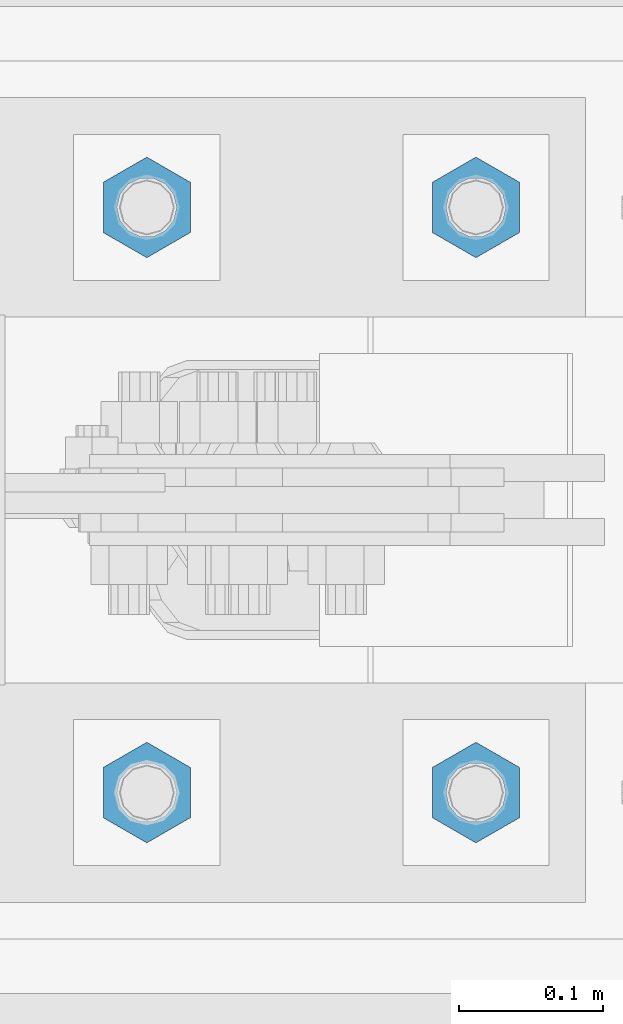
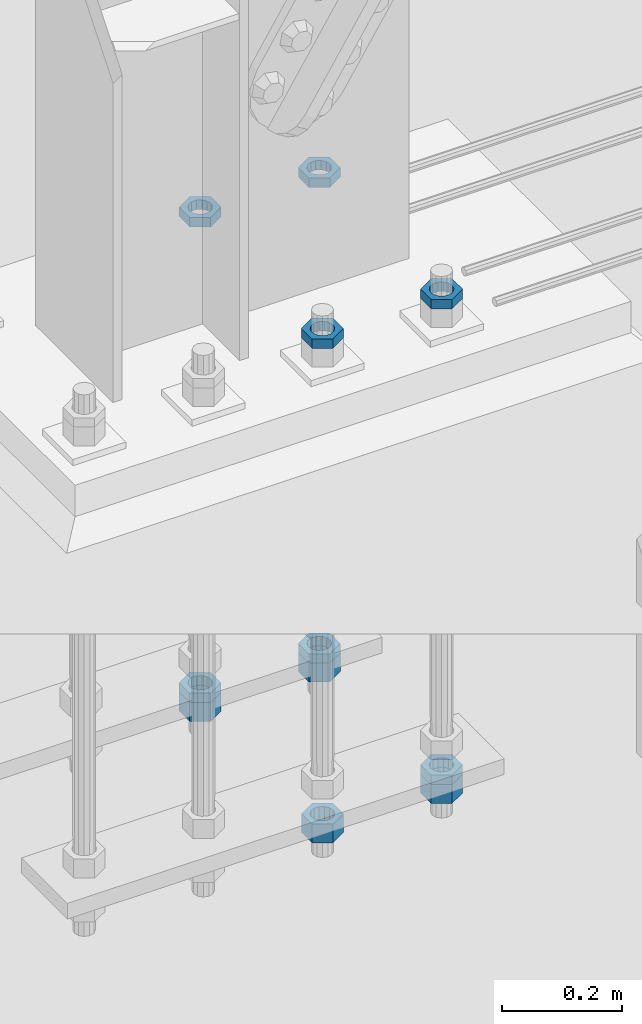
# One storey, part 2864 of 3843: 11 beams, 1 element without a shape of its own.
"""IFC2X3 building model written with IfcOpenShell, lengths in millimetres."""

from ifc_helpers import new_model, si_unit, frame, origin_with_axes, place, context, subcontext, project, spatial, faceted_brep, material, type_object, element, aggregate, save


model = new_model("IFC2X3")

# Units and contexts
model_context = context("Model", 3, precision=1e-05, world=origin_with_axes())
body_context = subcontext(model_context, "Body", "Model", "MODEL_VIEW")
ifc_project = project(units=[si_unit("LENGTHUNIT", "METRE", prefix="MILLI"), si_unit("AREAUNIT", "SQUARE_METRE"), si_unit("VOLUMEUNIT", "CUBIC_METRE"), si_unit("MASSUNIT", "GRAM", prefix="KILO"), si_unit("TIMEUNIT", "SECOND"), si_unit("PLANEANGLEUNIT", "RADIAN"), si_unit("SOLIDANGLEUNIT", "STERADIAN"), si_unit("THERMODYNAMICTEMPERATUREUNIT", "DEGREE_CELSIUS"), si_unit("LUMINOUSINTENSITYUNIT", "LUMEN")], contexts=[model_context])

# Site, building, storey
site_placement = place(None, origin_with_axes())
site = spatial("IfcSite", under=ifc_project, at=site_placement, CompositionType="ELEMENT")
building_placement = place(site_placement, origin_with_axes())
building = spatial("IfcBuilding", under=site, at=building_placement, Name="Undefined", CompositionType="ELEMENT")
storey_placement = place(building_placement, origin_with_axes())
storey = spatial("IfcBuildingStorey", under=building, at=storey_placement, Name="Undefined", CompositionType="ELEMENT", Elevation=0.0)

# Assembly, beams
assembly_placement = place(storey_placement, origin_with_axes())
assembly = element("IfcElementAssembly", 1, at=assembly_placement, inside=storey, Name="TEMPLATE", AssemblyPlace="NOTDEFINED", PredefinedType="RIGID_FRAME")
ifc_material = material(Name="STEEL/A572-50")
beam_type_1 = type_object("IfcBeamType", Name="1-1/2_HEAVY_HEX_NUT", PredefinedType="NOTDEFINED")
beam_1_placement = place(assembly_placement, frame((23317.1999804674, 89319.1, 29210.0), z_axis=(-1.0, 0.0, 0.0), x_axis=(0.0, 0.0, -1.0)))
beam_1 = element("IfcBeam", 2, at=beam_1_placement, type_object=beam_type_1, material=ifc_material, Name="NUT", ObjectType="1-1/2_HEAVY_HEX_NUT", context=body_context, shape_type="Brep", body=[
    faceted_brep([(0.0, -34.9199981689453, 0.0), (0.0, -17.4599990844727, -30.25), (38.0999999999985, -17.4599990844727, -30.25), (38.0999999999985, -34.9199981689453, 0.0), (0.0, 17.4599990844727, -30.25), (38.0999999999985, 17.4599990844727, -30.25), (0.0, 34.9199981689453, 0.0), (38.0999999999985, 34.9199981689453, 0.0), (0.0, 17.4599990844727, 30.25), (38.0999999999985, 17.4599990844727, 30.25), (0.0, -17.4599990844727, 30.25), (38.0999999999985, -17.4599990844727, 30.25), (0.0, 0.0, 20.6399993896484), (0.0, 8.9553601105581, 18.5959968835959), (38.0999999999985, 8.9553601105581, 18.5959968835959), (38.0999999999985, 0.0, 20.6399993896484), (0.0, 16.1370013209525, 12.8688291298167), (38.0999999999985, 16.1370013209525, 12.8688291298167), (0.0, 20.1225115123816, 4.59283194104501), (38.0999999999985, 20.1225115123816, 4.59283194104501), (0.0, 20.1225115123816, -4.59283194104501), (38.0999999999985, 20.1225115123816, -4.59283194104501), (0.0, 16.1370013209525, -12.8688291298167), (38.0999999999985, 16.1370013209525, -12.8688291298167), (0.0, 8.9553601105581, -18.5959968835959), (38.0999999999985, 8.9553601105581, -18.5959968835959), (0.0, 0.0, -20.6399993896484), (38.0999999999985, 0.0, -20.6399993896484), (0.0, -8.9553601105581, -18.5959968835959), (38.0999999999985, -8.9553601105581, -18.5959968835959), (0.0, -16.1370013209525, -12.8688291298167), (38.0999999999985, -16.1370013209525, -12.8688291298167), (0.0, -20.1225115123816, -4.59283194104501), (38.0999999999985, -20.1225115123816, -4.59283194104501), (0.0, -20.1225115123816, 4.59283194104501), (38.0999999999985, -20.1225115123816, 4.59283194104501), (0.0, -16.1370013209525, 12.8688291298167), (38.0999999999985, -16.1370013209525, 12.8688291298167), (0.0, -8.9553601105581, 18.5959968835959), (38.0999999999985, -8.9553601105581, 18.5959968835959)], [[[0, 1, 2, 3]], [[1, 4, 5, 2]], [[4, 6, 7, 5]], [[6, 8, 9, 7]], [[8, 10, 11, 9]], [[10, 0, 3, 11]], [[12, 13, 14, 15]], [[13, 16, 17, 14]], [[16, 18, 19, 17]], [[18, 20, 21, 19]], [[20, 22, 23, 21]], [[22, 24, 25, 23]], [[24, 26, 27, 25]], [[26, 28, 29, 27]], [[28, 30, 31, 29]], [[30, 32, 33, 31]], [[32, 34, 35, 33]], [[34, 36, 37, 35]], [[36, 38, 39, 37]], [[38, 12, 15, 39]], [[5, 7, 9, 11, 3, 2], [17, 19, 21, 23, 25, 27, 29, 31, 33, 35, 37, 39, 15, 14]], [[10, 8, 6, 4, 1, 0], [38, 36, 34, 32, 30, 28, 26, 24, 22, 20, 18, 16, 13, 12]]]),
])
beam_2_placement = place(assembly_placement, frame((23317.2000195326, 88912.7, 29210.0), z_axis=(1.0, 0.0, 0.0), x_axis=(0.0, 0.0, -1.0)))
beam_2 = element("IfcBeam", 3, at=beam_2_placement, type_object=beam_type_1, material=ifc_material, Name="NUT", ObjectType="1-1/2_HEAVY_HEX_NUT", context=body_context, shape_type="Brep", body=[
    faceted_brep([(0.0, -34.9199981689453, 0.0), (0.0, -17.4599990844727, -30.25), (38.0999999999985, -17.4599990844727, -30.25), (38.0999999999985, -34.9199981689453, 0.0), (0.0, 17.4599990844727, -30.25), (38.0999999999985, 17.4599990844727, -30.25), (0.0, 34.9199981689453, 0.0), (38.0999999999985, 34.9199981689453, 0.0), (0.0, 17.4599990844727, 30.25), (38.0999999999985, 17.4599990844727, 30.25), (0.0, -17.4599990844727, 30.25), (38.0999999999985, -17.4599990844727, 30.25), (0.0, 0.0, 20.6399993896484), (0.0, 8.9553601105581, 18.5959968835959), (38.0999999999985, 8.9553601105581, 18.5959968835959), (38.0999999999985, 0.0, 20.6399993896484), (0.0, 16.1370013209525, 12.8688291298167), (38.0999999999985, 16.1370013209525, 12.8688291298167), (0.0, 20.1225115123816, 4.59283194104501), (38.0999999999985, 20.1225115123816, 4.59283194104501), (0.0, 20.1225115123816, -4.59283194104501), (38.0999999999985, 20.1225115123816, -4.59283194104501), (0.0, 16.1370013209525, -12.8688291298167), (38.0999999999985, 16.1370013209525, -12.8688291298167), (0.0, 8.9553601105581, -18.5959968835959), (38.0999999999985, 8.9553601105581, -18.5959968835959), (0.0, 0.0, -20.6399993896484), (38.0999999999985, 0.0, -20.6399993896484), (0.0, -8.9553601105581, -18.5959968835959), (38.0999999999985, -8.9553601105581, -18.5959968835959), (0.0, -16.1370013209525, -12.8688291298167), (38.0999999999985, -16.1370013209525, -12.8688291298167), (0.0, -20.1225115123816, -4.59283194104501), (38.0999999999985, -20.1225115123816, -4.59283194104501), (0.0, -20.1225115123816, 4.59283194104501), (38.0999999999985, -20.1225115123816, 4.59283194104501), (0.0, -16.1370013209525, 12.8688291298167), (38.0999999999985, -16.1370013209525, 12.8688291298167), (0.0, -8.9553601105581, 18.5959968835959), (38.0999999999985, -8.9553601105581, 18.5959968835959)], [[[0, 1, 2, 3]], [[1, 4, 5, 2]], [[4, 6, 7, 5]], [[6, 8, 9, 7]], [[8, 10, 11, 9]], [[10, 0, 3, 11]], [[12, 13, 14, 15]], [[13, 16, 17, 14]], [[16, 18, 19, 17]], [[18, 20, 21, 19]], [[20, 22, 23, 21]], [[22, 24, 25, 23]], [[24, 26, 27, 25]], [[26, 28, 29, 27]], [[28, 30, 31, 29]], [[30, 32, 33, 31]], [[32, 34, 35, 33]], [[34, 36, 37, 35]], [[36, 38, 39, 37]], [[38, 12, 15, 39]], [[5, 7, 9, 11, 3, 2], [17, 19, 21, 23, 25, 27, 29, 31, 33, 35, 37, 39, 15, 14]], [[10, 8, 6, 4, 1, 0], [38, 36, 34, 32, 30, 28, 26, 24, 22, 20, 18, 16, 13, 12]]]),
])
beam_3_placement = place(assembly_placement, frame((23088.5999804674, 89319.1, 29210.0), z_axis=(-1.0, 0.0, 0.0), x_axis=(0.0, 0.0, -1.0)))
beam_3 = element("IfcBeam", 4, at=beam_3_placement, type_object=beam_type_1, material=ifc_material, Name="NUT", ObjectType="1-1/2_HEAVY_HEX_NUT", context=body_context, shape_type="Brep", body=[
    faceted_brep([(0.0, -34.9199981689453, 0.0), (0.0, -17.4599990844727, -30.25), (38.0999999999985, -17.4599990844727, -30.25), (38.0999999999985, -34.9199981689453, 0.0), (0.0, 17.4599990844727, -30.25), (38.0999999999985, 17.4599990844727, -30.25), (0.0, 34.9199981689453, 0.0), (38.0999999999985, 34.9199981689453, 0.0), (0.0, 17.4599990844727, 30.25), (38.0999999999985, 17.4599990844727, 30.25), (0.0, -17.4599990844727, 30.25), (38.0999999999985, -17.4599990844727, 30.25), (0.0, 0.0, 20.6399993896484), (0.0, 8.9553601105581, 18.5959968835959), (38.0999999999985, 8.9553601105581, 18.5959968835959), (38.0999999999985, 0.0, 20.6399993896484), (0.0, 16.1370013209525, 12.8688291298167), (38.0999999999985, 16.1370013209525, 12.8688291298167), (0.0, 20.1225115123816, 4.59283194104501), (38.0999999999985, 20.1225115123816, 4.59283194104501), (0.0, 20.1225115123816, -4.59283194104501), (38.0999999999985, 20.1225115123816, -4.59283194104501), (0.0, 16.1370013209525, -12.8688291298167), (38.0999999999985, 16.1370013209525, -12.8688291298167), (0.0, 8.9553601105581, -18.5959968835959), (38.0999999999985, 8.9553601105581, -18.5959968835959), (0.0, 0.0, -20.6399993896484), (38.0999999999985, 0.0, -20.6399993896484), (0.0, -8.9553601105581, -18.5959968835959), (38.0999999999985, -8.9553601105581, -18.5959968835959), (0.0, -16.1370013209525, -12.8688291298167), (38.0999999999985, -16.1370013209525, -12.8688291298167), (0.0, -20.1225115123816, -4.59283194104501), (38.0999999999985, -20.1225115123816, -4.59283194104501), (0.0, -20.1225115123816, 4.59283194104501), (38.0999999999985, -20.1225115123816, 4.59283194104501), (0.0, -16.1370013209525, 12.8688291298167), (38.0999999999985, -16.1370013209525, 12.8688291298167), (0.0, -8.9553601105581, 18.5959968835959), (38.0999999999985, -8.9553601105581, 18.5959968835959)], [[[0, 1, 2, 3]], [[1, 4, 5, 2]], [[4, 6, 7, 5]], [[6, 8, 9, 7]], [[8, 10, 11, 9]], [[10, 0, 3, 11]], [[12, 13, 14, 15]], [[13, 16, 17, 14]], [[16, 18, 19, 17]], [[18, 20, 21, 19]], [[20, 22, 23, 21]], [[22, 24, 25, 23]], [[24, 26, 27, 25]], [[26, 28, 29, 27]], [[28, 30, 31, 29]], [[30, 32, 33, 31]], [[32, 34, 35, 33]], [[34, 36, 37, 35]], [[36, 38, 39, 37]], [[38, 12, 15, 39]], [[5, 7, 9, 11, 3, 2], [17, 19, 21, 23, 25, 27, 29, 31, 33, 35, 37, 39, 15, 14]], [[10, 8, 6, 4, 1, 0], [38, 36, 34, 32, 30, 28, 26, 24, 22, 20, 18, 16, 13, 12]]]),
])
beam_4_placement = place(assembly_placement, frame((23088.6000195326, 88912.7, 29210.0), z_axis=(1.0, 0.0, 0.0), x_axis=(0.0, 0.0, -1.0)))
beam_4 = element("IfcBeam", 5, at=beam_4_placement, type_object=beam_type_1, material=ifc_material, Name="NUT", ObjectType="1-1/2_HEAVY_HEX_NUT", context=body_context, shape_type="Brep", body=[
    faceted_brep([(0.0, -34.9199981689453, 0.0), (0.0, -17.4599990844727, -30.25), (38.0999999999985, -17.4599990844727, -30.25), (38.0999999999985, -34.9199981689453, 0.0), (0.0, 17.4599990844727, -30.25), (38.0999999999985, 17.4599990844727, -30.25), (0.0, 34.9199981689453, 0.0), (38.0999999999985, 34.9199981689453, 0.0), (0.0, 17.4599990844727, 30.25), (38.0999999999985, 17.4599990844727, 30.25), (0.0, -17.4599990844727, 30.25), (38.0999999999985, -17.4599990844727, 30.25), (0.0, 0.0, 20.6399993896484), (0.0, 8.9553601105581, 18.5959968835959), (38.0999999999985, 8.9553601105581, 18.5959968835959), (38.0999999999985, 0.0, 20.6399993896484), (0.0, 16.1370013209525, 12.8688291298167), (38.0999999999985, 16.1370013209525, 12.8688291298167), (0.0, 20.1225115123816, 4.59283194104501), (38.0999999999985, 20.1225115123816, 4.59283194104501), (0.0, 20.1225115123816, -4.59283194104501), (38.0999999999985, 20.1225115123816, -4.59283194104501), (0.0, 16.1370013209525, -12.8688291298167), (38.0999999999985, 16.1370013209525, -12.8688291298167), (0.0, 8.9553601105581, -18.5959968835959), (38.0999999999985, 8.9553601105581, -18.5959968835959), (0.0, 0.0, -20.6399993896484), (38.0999999999985, 0.0, -20.6399993896484), (0.0, -8.9553601105581, -18.5959968835959), (38.0999999999985, -8.9553601105581, -18.5959968835959), (0.0, -16.1370013209525, -12.8688291298167), (38.0999999999985, -16.1370013209525, -12.8688291298167), (0.0, -20.1225115123816, -4.59283194104501), (38.0999999999985, -20.1225115123816, -4.59283194104501), (0.0, -20.1225115123816, 4.59283194104501), (38.0999999999985, -20.1225115123816, 4.59283194104501), (0.0, -16.1370013209525, 12.8688291298167), (38.0999999999985, -16.1370013209525, 12.8688291298167), (0.0, -8.9553601105581, 18.5959968835959), (38.0999999999985, -8.9553601105581, 18.5959968835959)], [[[0, 1, 2, 3]], [[1, 4, 5, 2]], [[4, 6, 7, 5]], [[6, 8, 9, 7]], [[8, 10, 11, 9]], [[10, 0, 3, 11]], [[12, 13, 14, 15]], [[13, 16, 17, 14]], [[16, 18, 19, 17]], [[18, 20, 21, 19]], [[20, 22, 23, 21]], [[22, 24, 25, 23]], [[24, 26, 27, 25]], [[26, 28, 29, 27]], [[28, 30, 31, 29]], [[30, 32, 33, 31]], [[32, 34, 35, 33]], [[34, 36, 37, 35]], [[36, 38, 39, 37]], [[38, 12, 15, 39]], [[5, 7, 9, 11, 3, 2], [17, 19, 21, 23, 25, 27, 29, 31, 33, 35, 37, 39, 15, 14]], [[10, 8, 6, 4, 1, 0], [38, 36, 34, 32, 30, 28, 26, 24, 22, 20, 18, 16, 13, 12]]]),
])
beam_type_2 = type_object("IfcBeamType", Name="1-1/2_HALF_NUT", PredefinedType="NOTDEFINED")
beam_5_placement = place(assembly_placement, frame((23317.1999755846, 89319.1, 30194.25), z_axis=(-1.0, 0.0, 0.0), x_axis=(0.0, 0.0, -1.0)))
beam_5 = element("IfcBeam", 6, at=beam_5_placement, type_object=beam_type_2, material=ifc_material, Name="NUT", ObjectType="1-1/2_HALF_NUT", context=body_context, shape_type="Brep", body=[
    faceted_brep([(0.0, -34.9199981689453, 0.0), (0.0, -17.4599990844727, -30.25), (19.0500000000029, -17.4599990844727, -30.25), (19.0500000000029, -34.9199981689453, 0.0), (0.0, 17.4599990844727, -30.25), (19.0500000000029, 17.4599990844727, -30.25), (0.0, 34.9199981689453, 0.0), (19.0500000000029, 34.9199981689453, 0.0), (0.0, 17.4599990844727, 30.25), (19.0500000000029, 17.4599990844727, 30.25), (0.0, -17.4599990844727, 30.25), (19.0500000000029, -17.4599990844727, 30.25), (0.0, 0.0, 20.6399993896484), (0.0, 8.9553601105581, 18.5959968835959), (19.0500000000029, 8.95536011056538, 18.5959968835959), (19.0500000000029, 0.0, 20.6399993896484), (0.0, 16.1370013209525, 12.8688291298167), (19.0500000000029, 16.1370013209489, 12.8688291298167), (0.0, 20.1225115123816, 4.59283194104501), (19.0500000000029, 20.1225115123852, 4.59283194104501), (0.0, 20.1225115123816, -4.59283194104501), (19.0500000000029, 20.1225115123852, -4.59283194104501), (0.0, 16.1370013209525, -12.8688291298167), (19.0500000000029, 16.1370013209489, -12.8688291298167), (0.0, 8.9553601105581, -18.5959968835959), (19.0500000000029, 8.95536011056538, -18.5959968835959), (0.0, 0.0, -20.6399993896484), (19.0500000000029, 0.0, -20.6399993896484), (0.0, -8.9553601105581, -18.5959968835959), (19.0500000000029, -8.95536011056538, -18.5959968835959), (0.0, -16.1370013209525, -12.8688291298167), (19.0500000000029, -16.1370013209489, -12.8688291298167), (0.0, -20.1225115123816, -4.59283194104501), (19.0500000000029, -20.1225115123852, -4.59283194104501), (0.0, -20.1225115123816, 4.59283194104501), (19.0500000000029, -20.1225115123852, 4.59283194104501), (0.0, -16.1370013209525, 12.8688291298167), (19.0500000000029, -16.1370013209489, 12.8688291298167), (0.0, -8.9553601105581, 18.5959968835959), (19.0500000000029, -8.95536011056538, 18.5959968835959)], [[[0, 1, 2, 3]], [[1, 4, 5, 2]], [[4, 6, 7, 5]], [[6, 8, 9, 7]], [[8, 10, 11, 9]], [[10, 0, 3, 11]], [[12, 13, 14, 15]], [[13, 16, 17, 14]], [[16, 18, 19, 17]], [[18, 20, 21, 19]], [[20, 22, 23, 21]], [[22, 24, 25, 23]], [[24, 26, 27, 25]], [[26, 28, 29, 27]], [[28, 30, 31, 29]], [[30, 32, 33, 31]], [[32, 34, 35, 33]], [[34, 36, 37, 35]], [[36, 38, 39, 37]], [[38, 12, 15, 39]], [[5, 7, 9, 11, 3, 2], [17, 19, 21, 23, 25, 27, 29, 31, 33, 35, 37, 39, 15, 14]], [[10, 8, 6, 4, 1, 0], [38, 36, 34, 32, 30, 28, 26, 24, 22, 20, 18, 16, 13, 12]]]),
])
beam_6_placement = place(assembly_placement, frame((23317.1999877916, 89319.1, 29229.05), z_axis=(-1.0, 0.0, 0.0), x_axis=(0.0, 0.0, -1.0)))
beam_6 = element("IfcBeam", 7, at=beam_6_placement, type_object=beam_type_2, material=ifc_material, Name="NUT", ObjectType="1-1/2_HALF_NUT", context=body_context, shape_type="Brep", body=[
    faceted_brep([(0.0, -34.9199981689453, 0.0), (0.0, -17.4599990844727, -30.25), (19.0500000000029, -17.4599990844727, -30.25), (19.0500000000029, -34.9199981689453, 0.0), (0.0, 17.4599990844727, -30.25), (19.0500000000029, 17.4599990844727, -30.25), (0.0, 34.9199981689453, 0.0), (19.0500000000029, 34.9199981689453, 0.0), (0.0, 17.4599990844727, 30.25), (19.0500000000029, 17.4599990844727, 30.25), (0.0, -17.4599990844727, 30.25), (19.0500000000029, -17.4599990844727, 30.25), (0.0, 0.0, 20.6399993896484), (0.0, 8.9553601105581, 18.5959968835959), (19.0500000000029, 8.95536011056538, 18.5959968835959), (19.0500000000029, 0.0, 20.6399993896484), (0.0, 16.1370013209525, 12.8688291298167), (19.0500000000029, 16.1370013209489, 12.8688291298167), (0.0, 20.1225115123816, 4.59283194104501), (19.0500000000029, 20.1225115123852, 4.59283194104501), (0.0, 20.1225115123816, -4.59283194104501), (19.0500000000029, 20.1225115123852, -4.59283194104501), (0.0, 16.1370013209525, -12.8688291298167), (19.0500000000029, 16.1370013209489, -12.8688291298167), (0.0, 8.9553601105581, -18.5959968835959), (19.0500000000029, 8.95536011056538, -18.5959968835959), (0.0, 0.0, -20.6399993896484), (19.0500000000029, 0.0, -20.6399993896484), (0.0, -8.9553601105581, -18.5959968835959), (19.0500000000029, -8.95536011056538, -18.5959968835959), (0.0, -16.1370013209525, -12.8688291298167), (19.0500000000029, -16.1370013209489, -12.8688291298167), (0.0, -20.1225115123816, -4.59283194104501), (19.0500000000029, -20.1225115123852, -4.59283194104501), (0.0, -20.1225115123816, 4.59283194104501), (19.0500000000029, -20.1225115123852, 4.59283194104501), (0.0, -16.1370013209525, 12.8688291298167), (19.0500000000029, -16.1370013209489, 12.8688291298167), (0.0, -8.9553601105581, 18.5959968835959), (19.0500000000029, -8.95536011056538, 18.5959968835959)], [[[0, 1, 2, 3]], [[1, 4, 5, 2]], [[4, 6, 7, 5]], [[6, 8, 9, 7]], [[8, 10, 11, 9]], [[10, 0, 3, 11]], [[12, 13, 14, 15]], [[13, 16, 17, 14]], [[16, 18, 19, 17]], [[18, 20, 21, 19]], [[20, 22, 23, 21]], [[22, 24, 25, 23]], [[24, 26, 27, 25]], [[26, 28, 29, 27]], [[28, 30, 31, 29]], [[30, 32, 33, 31]], [[32, 34, 35, 33]], [[34, 36, 37, 35]], [[36, 38, 39, 37]], [[38, 12, 15, 39]], [[5, 7, 9, 11, 3, 2], [17, 19, 21, 23, 25, 27, 29, 31, 33, 35, 37, 39, 15, 14]], [[10, 8, 6, 4, 1, 0], [38, 36, 34, 32, 30, 28, 26, 24, 22, 20, 18, 16, 13, 12]]]),
])
beam_7_placement = place(assembly_placement, frame((23317.2000244154, 88912.7, 30194.25), z_axis=(1.0, 0.0, 0.0), x_axis=(0.0, 0.0, -1.0)))
beam_7 = element("IfcBeam", 8, at=beam_7_placement, type_object=beam_type_2, material=ifc_material, Name="NUT", ObjectType="1-1/2_HALF_NUT", context=body_context, shape_type="Brep", body=[
    faceted_brep([(0.0, -34.9199981689453, 0.0), (0.0, -17.4599990844727, -30.25), (19.0500000000029, -17.4599990844727, -30.25), (19.0500000000029, -34.9199981689453, 0.0), (0.0, 17.4599990844727, -30.25), (19.0500000000029, 17.4599990844727, -30.25), (0.0, 34.9199981689453, 0.0), (19.0500000000029, 34.9199981689453, 0.0), (0.0, 17.4599990844727, 30.25), (19.0500000000029, 17.4599990844727, 30.25), (0.0, -17.4599990844727, 30.25), (19.0500000000029, -17.4599990844727, 30.25), (0.0, 0.0, 20.6399993896484), (0.0, 8.9553601105581, 18.5959968835959), (19.0500000000029, 8.95536011056538, 18.5959968835959), (19.0500000000029, 0.0, 20.6399993896484), (0.0, 16.1370013209525, 12.8688291298167), (19.0500000000029, 16.1370013209489, 12.8688291298167), (0.0, 20.1225115123816, 4.59283194104501), (19.0500000000029, 20.1225115123852, 4.59283194104501), (0.0, 20.1225115123816, -4.59283194104501), (19.0500000000029, 20.1225115123852, -4.59283194104501), (0.0, 16.1370013209525, -12.8688291298167), (19.0500000000029, 16.1370013209489, -12.8688291298167), (0.0, 8.9553601105581, -18.5959968835959), (19.0500000000029, 8.95536011056538, -18.5959968835959), (0.0, 0.0, -20.6399993896484), (19.0500000000029, 0.0, -20.6399993896484), (0.0, -8.9553601105581, -18.5959968835959), (19.0500000000029, -8.95536011056538, -18.5959968835959), (0.0, -16.1370013209525, -12.8688291298167), (19.0500000000029, -16.1370013209489, -12.8688291298167), (0.0, -20.1225115123816, -4.59283194104501), (19.0500000000029, -20.1225115123852, -4.59283194104501), (0.0, -20.1225115123816, 4.59283194104501), (19.0500000000029, -20.1225115123852, 4.59283194104501), (0.0, -16.1370013209525, 12.8688291298167), (19.0500000000029, -16.1370013209489, 12.8688291298167), (0.0, -8.9553601105581, 18.5959968835959), (19.0500000000029, -8.95536011056538, 18.5959968835959)], [[[0, 1, 2, 3]], [[1, 4, 5, 2]], [[4, 6, 7, 5]], [[6, 8, 9, 7]], [[8, 10, 11, 9]], [[10, 0, 3, 11]], [[12, 13, 14, 15]], [[13, 16, 17, 14]], [[16, 18, 19, 17]], [[18, 20, 21, 19]], [[20, 22, 23, 21]], [[22, 24, 25, 23]], [[24, 26, 27, 25]], [[26, 28, 29, 27]], [[28, 30, 31, 29]], [[30, 32, 33, 31]], [[32, 34, 35, 33]], [[34, 36, 37, 35]], [[36, 38, 39, 37]], [[38, 12, 15, 39]], [[5, 7, 9, 11, 3, 2], [17, 19, 21, 23, 25, 27, 29, 31, 33, 35, 37, 39, 15, 14]], [[10, 8, 6, 4, 1, 0], [38, 36, 34, 32, 30, 28, 26, 24, 22, 20, 18, 16, 13, 12]]]),
])
beam_8_placement = place(assembly_placement, frame((23317.2000122084, 88912.7, 29229.05), z_axis=(1.0, 0.0, 0.0), x_axis=(0.0, 0.0, -1.0)))
beam_8 = element("IfcBeam", 9, at=beam_8_placement, type_object=beam_type_2, material=ifc_material, Name="NUT", ObjectType="1-1/2_HALF_NUT", context=body_context, shape_type="Brep", body=[
    faceted_brep([(0.0, -34.9199981689453, 0.0), (0.0, -17.4599990844727, -30.25), (19.0500000000029, -17.4599990844727, -30.25), (19.0500000000029, -34.9199981689453, 0.0), (0.0, 17.4599990844727, -30.25), (19.0500000000029, 17.4599990844727, -30.25), (0.0, 34.9199981689453, 0.0), (19.0500000000029, 34.9199981689453, 0.0), (0.0, 17.4599990844727, 30.25), (19.0500000000029, 17.4599990844727, 30.25), (0.0, -17.4599990844727, 30.25), (19.0500000000029, -17.4599990844727, 30.25), (0.0, 0.0, 20.6399993896484), (0.0, 8.9553601105581, 18.5959968835959), (19.0500000000029, 8.95536011056538, 18.5959968835959), (19.0500000000029, 0.0, 20.6399993896484), (0.0, 16.1370013209525, 12.8688291298167), (19.0500000000029, 16.1370013209489, 12.8688291298167), (0.0, 20.1225115123816, 4.59283194104501), (19.0500000000029, 20.1225115123852, 4.59283194104501), (0.0, 20.1225115123816, -4.59283194104501), (19.0500000000029, 20.1225115123852, -4.59283194104501), (0.0, 16.1370013209525, -12.8688291298167), (19.0500000000029, 16.1370013209489, -12.8688291298167), (0.0, 8.9553601105581, -18.5959968835959), (19.0500000000029, 8.95536011056538, -18.5959968835959), (0.0, 0.0, -20.6399993896484), (19.0500000000029, 0.0, -20.6399993896484), (0.0, -8.9553601105581, -18.5959968835959), (19.0500000000029, -8.95536011056538, -18.5959968835959), (0.0, -16.1370013209525, -12.8688291298167), (19.0500000000029, -16.1370013209489, -12.8688291298167), (0.0, -20.1225115123816, -4.59283194104501), (19.0500000000029, -20.1225115123852, -4.59283194104501), (0.0, -20.1225115123816, 4.59283194104501), (19.0500000000029, -20.1225115123852, 4.59283194104501), (0.0, -16.1370013209525, 12.8688291298167), (19.0500000000029, -16.1370013209489, 12.8688291298167), (0.0, -8.9553601105581, 18.5959968835959), (19.0500000000029, -8.95536011056538, 18.5959968835959)], [[[0, 1, 2, 3]], [[1, 4, 5, 2]], [[4, 6, 7, 5]], [[6, 8, 9, 7]], [[8, 10, 11, 9]], [[10, 0, 3, 11]], [[12, 13, 14, 15]], [[13, 16, 17, 14]], [[16, 18, 19, 17]], [[18, 20, 21, 19]], [[20, 22, 23, 21]], [[22, 24, 25, 23]], [[24, 26, 27, 25]], [[26, 28, 29, 27]], [[28, 30, 31, 29]], [[30, 32, 33, 31]], [[32, 34, 35, 33]], [[34, 36, 37, 35]], [[36, 38, 39, 37]], [[38, 12, 15, 39]], [[5, 7, 9, 11, 3, 2], [17, 19, 21, 23, 25, 27, 29, 31, 33, 35, 37, 39, 15, 14]], [[10, 8, 6, 4, 1, 0], [38, 36, 34, 32, 30, 28, 26, 24, 22, 20, 18, 16, 13, 12]]]),
])
beam_9_placement = place(assembly_placement, frame((23088.5999755846, 89319.1, 30194.25), z_axis=(-1.0, 0.0, 0.0), x_axis=(0.0, 0.0, -1.0)))
beam_9 = element("IfcBeam", 10, at=beam_9_placement, type_object=beam_type_2, material=ifc_material, Name="NUT", ObjectType="1-1/2_HALF_NUT", context=body_context, shape_type="Brep", body=[
    faceted_brep([(0.0, -34.9199981689453, 0.0), (0.0, -17.4599990844727, -30.25), (19.0500000000029, -17.4599990844727, -30.25), (19.0500000000029, -34.9199981689453, 0.0), (0.0, 17.4599990844727, -30.25), (19.0500000000029, 17.4599990844727, -30.25), (0.0, 34.9199981689453, 0.0), (19.0500000000029, 34.9199981689453, 0.0), (0.0, 17.4599990844727, 30.25), (19.0500000000029, 17.4599990844727, 30.25), (0.0, -17.4599990844727, 30.25), (19.0500000000029, -17.4599990844727, 30.25), (0.0, 0.0, 20.6399993896484), (0.0, 8.9553601105581, 18.5959968835959), (19.0500000000029, 8.95536011056538, 18.5959968835959), (19.0500000000029, 0.0, 20.6399993896484), (0.0, 16.1370013209525, 12.8688291298167), (19.0500000000029, 16.1370013209489, 12.8688291298167), (0.0, 20.1225115123816, 4.59283194104501), (19.0500000000029, 20.1225115123852, 4.59283194104501), (0.0, 20.1225115123816, -4.59283194104501), (19.0500000000029, 20.1225115123852, -4.59283194104501), (0.0, 16.1370013209525, -12.8688291298167), (19.0500000000029, 16.1370013209489, -12.8688291298167), (0.0, 8.9553601105581, -18.5959968835959), (19.0500000000029, 8.95536011056538, -18.5959968835959), (0.0, 0.0, -20.6399993896484), (19.0500000000029, 0.0, -20.6399993896484), (0.0, -8.9553601105581, -18.5959968835959), (19.0500000000029, -8.95536011056538, -18.5959968835959), (0.0, -16.1370013209525, -12.8688291298167), (19.0500000000029, -16.1370013209489, -12.8688291298167), (0.0, -20.1225115123816, -4.59283194104501), (19.0500000000029, -20.1225115123852, -4.59283194104501), (0.0, -20.1225115123816, 4.59283194104501), (19.0500000000029, -20.1225115123852, 4.59283194104501), (0.0, -16.1370013209525, 12.8688291298167), (19.0500000000029, -16.1370013209489, 12.8688291298167), (0.0, -8.9553601105581, 18.5959968835959), (19.0500000000029, -8.95536011056538, 18.5959968835959)], [[[0, 1, 2, 3]], [[1, 4, 5, 2]], [[4, 6, 7, 5]], [[6, 8, 9, 7]], [[8, 10, 11, 9]], [[10, 0, 3, 11]], [[12, 13, 14, 15]], [[13, 16, 17, 14]], [[16, 18, 19, 17]], [[18, 20, 21, 19]], [[20, 22, 23, 21]], [[22, 24, 25, 23]], [[24, 26, 27, 25]], [[26, 28, 29, 27]], [[28, 30, 31, 29]], [[30, 32, 33, 31]], [[32, 34, 35, 33]], [[34, 36, 37, 35]], [[36, 38, 39, 37]], [[38, 12, 15, 39]], [[5, 7, 9, 11, 3, 2], [17, 19, 21, 23, 25, 27, 29, 31, 33, 35, 37, 39, 15, 14]], [[10, 8, 6, 4, 1, 0], [38, 36, 34, 32, 30, 28, 26, 24, 22, 20, 18, 16, 13, 12]]]),
])
beam_10_placement = place(assembly_placement, frame((23088.5999877916, 89319.1, 29229.05), z_axis=(-1.0, 0.0, 0.0), x_axis=(0.0, 0.0, -1.0)))
beam_10 = element("IfcBeam", 11, at=beam_10_placement, type_object=beam_type_2, material=ifc_material, Name="NUT", ObjectType="1-1/2_HALF_NUT", context=body_context, shape_type="Brep", body=[
    faceted_brep([(0.0, -34.9199981689453, 0.0), (0.0, -17.4599990844727, -30.25), (19.0500000000029, -17.4599990844727, -30.25), (19.0500000000029, -34.9199981689453, 0.0), (0.0, 17.4599990844727, -30.25), (19.0500000000029, 17.4599990844727, -30.25), (0.0, 34.9199981689453, 0.0), (19.0500000000029, 34.9199981689453, 0.0), (0.0, 17.4599990844727, 30.25), (19.0500000000029, 17.4599990844727, 30.25), (0.0, -17.4599990844727, 30.25), (19.0500000000029, -17.4599990844727, 30.25), (0.0, 0.0, 20.6399993896484), (0.0, 8.9553601105581, 18.5959968835959), (19.0500000000029, 8.95536011056538, 18.5959968835959), (19.0500000000029, 0.0, 20.6399993896484), (0.0, 16.1370013209525, 12.8688291298167), (19.0500000000029, 16.1370013209489, 12.8688291298167), (0.0, 20.1225115123816, 4.59283194104501), (19.0500000000029, 20.1225115123852, 4.59283194104501), (0.0, 20.1225115123816, -4.59283194104501), (19.0500000000029, 20.1225115123852, -4.59283194104501), (0.0, 16.1370013209525, -12.8688291298167), (19.0500000000029, 16.1370013209489, -12.8688291298167), (0.0, 8.9553601105581, -18.5959968835959), (19.0500000000029, 8.95536011056538, -18.5959968835959), (0.0, 0.0, -20.6399993896484), (19.0500000000029, 0.0, -20.6399993896484), (0.0, -8.9553601105581, -18.5959968835959), (19.0500000000029, -8.95536011056538, -18.5959968835959), (0.0, -16.1370013209525, -12.8688291298167), (19.0500000000029, -16.1370013209489, -12.8688291298167), (0.0, -20.1225115123816, -4.59283194104501), (19.0500000000029, -20.1225115123852, -4.59283194104501), (0.0, -20.1225115123816, 4.59283194104501), (19.0500000000029, -20.1225115123852, 4.59283194104501), (0.0, -16.1370013209525, 12.8688291298167), (19.0500000000029, -16.1370013209489, 12.8688291298167), (0.0, -8.9553601105581, 18.5959968835959), (19.0500000000029, -8.95536011056538, 18.5959968835959)], [[[0, 1, 2, 3]], [[1, 4, 5, 2]], [[4, 6, 7, 5]], [[6, 8, 9, 7]], [[8, 10, 11, 9]], [[10, 0, 3, 11]], [[12, 13, 14, 15]], [[13, 16, 17, 14]], [[16, 18, 19, 17]], [[18, 20, 21, 19]], [[20, 22, 23, 21]], [[22, 24, 25, 23]], [[24, 26, 27, 25]], [[26, 28, 29, 27]], [[28, 30, 31, 29]], [[30, 32, 33, 31]], [[32, 34, 35, 33]], [[34, 36, 37, 35]], [[36, 38, 39, 37]], [[38, 12, 15, 39]], [[5, 7, 9, 11, 3, 2], [17, 19, 21, 23, 25, 27, 29, 31, 33, 35, 37, 39, 15, 14]], [[10, 8, 6, 4, 1, 0], [38, 36, 34, 32, 30, 28, 26, 24, 22, 20, 18, 16, 13, 12]]]),
])
beam_11_placement = place(assembly_placement, frame((23088.6000244154, 88912.7, 30194.25), z_axis=(1.0, 0.0, 0.0), x_axis=(0.0, 0.0, -1.0)))
beam_11 = element("IfcBeam", 12, at=beam_11_placement, type_object=beam_type_2, material=ifc_material, Name="NUT", ObjectType="1-1/2_HALF_NUT", context=body_context, shape_type="Brep", body=[
    faceted_brep([(0.0, -34.9199981689453, 0.0), (0.0, -17.4599990844727, -30.25), (19.0500000000029, -17.4599990844727, -30.25), (19.0500000000029, -34.9199981689453, 0.0), (0.0, 17.4599990844727, -30.25), (19.0500000000029, 17.4599990844727, -30.25), (0.0, 34.9199981689453, 0.0), (19.0500000000029, 34.9199981689453, 0.0), (0.0, 17.4599990844727, 30.25), (19.0500000000029, 17.4599990844727, 30.25), (0.0, -17.4599990844727, 30.25), (19.0500000000029, -17.4599990844727, 30.25), (0.0, 0.0, 20.6399993896484), (0.0, 8.9553601105581, 18.5959968835959), (19.0500000000029, 8.95536011056538, 18.5959968835959), (19.0500000000029, 0.0, 20.6399993896484), (0.0, 16.1370013209525, 12.8688291298167), (19.0500000000029, 16.1370013209489, 12.8688291298167), (0.0, 20.1225115123816, 4.59283194104501), (19.0500000000029, 20.1225115123852, 4.59283194104501), (0.0, 20.1225115123816, -4.59283194104501), (19.0500000000029, 20.1225115123852, -4.59283194104501), (0.0, 16.1370013209525, -12.8688291298167), (19.0500000000029, 16.1370013209489, -12.8688291298167), (0.0, 8.9553601105581, -18.5959968835959), (19.0500000000029, 8.95536011056538, -18.5959968835959), (0.0, 0.0, -20.6399993896484), (19.0500000000029, 0.0, -20.6399993896484), (0.0, -8.9553601105581, -18.5959968835959), (19.0500000000029, -8.95536011056538, -18.5959968835959), (0.0, -16.1370013209525, -12.8688291298167), (19.0500000000029, -16.1370013209489, -12.8688291298167), (0.0, -20.1225115123816, -4.59283194104501), (19.0500000000029, -20.1225115123852, -4.59283194104501), (0.0, -20.1225115123816, 4.59283194104501), (19.0500000000029, -20.1225115123852, 4.59283194104501), (0.0, -16.1370013209525, 12.8688291298167), (19.0500000000029, -16.1370013209489, 12.8688291298167), (0.0, -8.9553601105581, 18.5959968835959), (19.0500000000029, -8.95536011056538, 18.5959968835959)], [[[0, 1, 2, 3]], [[1, 4, 5, 2]], [[4, 6, 7, 5]], [[6, 8, 9, 7]], [[8, 10, 11, 9]], [[10, 0, 3, 11]], [[12, 13, 14, 15]], [[13, 16, 17, 14]], [[16, 18, 19, 17]], [[18, 20, 21, 19]], [[20, 22, 23, 21]], [[22, 24, 25, 23]], [[24, 26, 27, 25]], [[26, 28, 29, 27]], [[28, 30, 31, 29]], [[30, 32, 33, 31]], [[32, 34, 35, 33]], [[34, 36, 37, 35]], [[36, 38, 39, 37]], [[38, 12, 15, 39]], [[5, 7, 9, 11, 3, 2], [17, 19, 21, 23, 25, 27, 29, 31, 33, 35, 37, 39, 15, 14]], [[10, 8, 6, 4, 1, 0], [38, 36, 34, 32, 30, 28, 26, 24, 22, 20, 18, 16, 13, 12]]]),
])
aggregate(assembly, [beam_1, beam_5, beam_6, beam_2, beam_7, beam_8, beam_3, beam_9, beam_10, beam_4, beam_11])

save(model, "model.ifc")
